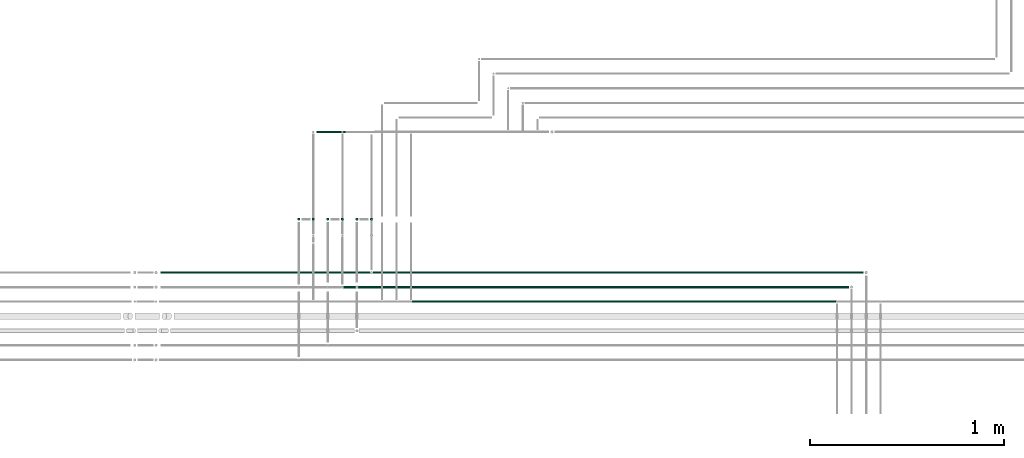
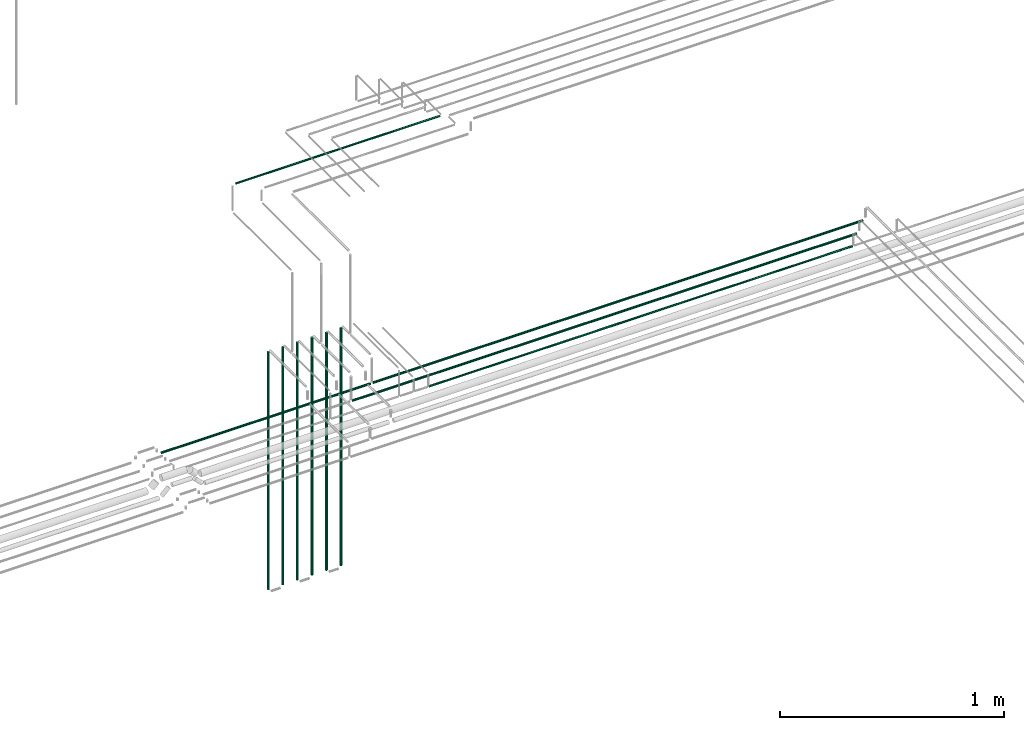
# One storey, part 29 of 331: 11 flow segments.
"""IFC2X3 building model written with IfcOpenShell, lengths in millimetres."""

from ifc_helpers import new_model, entity, si_unit, converted_unit, derived_unit, direction, frame, frame_2d, origin, origin_2d_with_axis, place, context, subcontext, project, spatial, circle, extrude, type_object, element, save


model = new_model("IFC2X3")

# Units and contexts
model_context = context("Model", 3, precision=0.01, world=origin(), true_north=direction((6.12303176911189e-17, 1.0)))
body_context = subcontext(model_context, "Body", "Model", "MODEL_VIEW")
ifc_project = project(units=[si_unit("LENGTHUNIT", "METRE", prefix="MILLI"), si_unit("AREAUNIT", "SQUARE_METRE"), si_unit("VOLUMEUNIT", "CUBIC_METRE"), converted_unit("PLANEANGLEUNIT", "DEGREE", entity("IfcRatioMeasure", 0.0174532925199433), si_unit("PLANEANGLEUNIT", "RADIAN"), dimensions=[0, 0, 0, 0, 0, 0, 0]), si_unit("MASSUNIT", "GRAM", prefix="KILO"), derived_unit("MASSDENSITYUNIT", [(si_unit("MASSUNIT", "GRAM", prefix="KILO"), 1), (si_unit("LENGTHUNIT", "METRE"), -3)]), derived_unit("MOMENTOFINERTIAUNIT", [(si_unit("LENGTHUNIT", "METRE"), 4)]), si_unit("TIMEUNIT", "SECOND"), si_unit("FREQUENCYUNIT", "HERTZ"), si_unit("THERMODYNAMICTEMPERATUREUNIT", "DEGREE_CELSIUS"), derived_unit("THERMALTRANSMITTANCEUNIT", [(si_unit("MASSUNIT", "GRAM", prefix="KILO"), 1), (si_unit("THERMODYNAMICTEMPERATUREUNIT", "KELVIN"), -1), (si_unit("TIMEUNIT", "SECOND"), -3)]), derived_unit("VOLUMETRICFLOWRATEUNIT", [(si_unit("LENGTHUNIT", "METRE"), 3), (si_unit("TIMEUNIT", "SECOND"), -1)]), derived_unit("MASSFLOWRATEUNIT", [(si_unit("MASSUNIT", "GRAM", prefix="KILO"), 1), (si_unit("TIMEUNIT", "SECOND"), -1)]), derived_unit("ROTATIONALFREQUENCYUNIT", [(si_unit("TIMEUNIT", "SECOND"), -1)]), si_unit("ELECTRICCURRENTUNIT", "AMPERE"), si_unit("ELECTRICVOLTAGEUNIT", "VOLT"), si_unit("POWERUNIT", "WATT"), si_unit("FORCEUNIT", "NEWTON", prefix="KILO"), si_unit("ILLUMINANCEUNIT", "LUX"), si_unit("LUMINOUSFLUXUNIT", "LUMEN"), si_unit("LUMINOUSINTENSITYUNIT", "CANDELA"), derived_unit("USERDEFINED", [(si_unit("MASSUNIT", "GRAM", prefix="KILO"), -1), (si_unit("LENGTHUNIT", "METRE"), -2), (si_unit("TIMEUNIT", "SECOND"), 3), (si_unit("LUMINOUSFLUXUNIT", "LUMEN"), 1)]), derived_unit("LINEARVELOCITYUNIT", [(si_unit("LENGTHUNIT", "METRE"), 1), (si_unit("TIMEUNIT", "SECOND"), -1)]), si_unit("PRESSUREUNIT", "PASCAL"), derived_unit("USERDEFINED", [(si_unit("LENGTHUNIT", "METRE"), -2), (si_unit("MASSUNIT", "GRAM", prefix="KILO"), 1), (si_unit("TIMEUNIT", "SECOND"), -2)]), derived_unit("LINEARFORCEUNIT", [(si_unit("MASSUNIT", "GRAM", prefix="KILO"), 1), (si_unit("LENGTHUNIT", "METRE"), 1), (si_unit("TIMEUNIT", "SECOND"), -2), (si_unit("LENGTHUNIT", "METRE"), -1)]), derived_unit("PLANARFORCEUNIT", [(si_unit("MASSUNIT", "GRAM", prefix="KILO"), 1), (si_unit("LENGTHUNIT", "METRE"), 1), (si_unit("TIMEUNIT", "SECOND"), -2), (si_unit("LENGTHUNIT", "METRE"), -2)])], contexts=[model_context])

# Site, building, storey
site_placement = place(None, frame((0.0, -0.00077364408347762, 0.0)))
site = spatial("IfcSite", under=ifc_project, at=site_placement, CompositionType="ELEMENT")
building_placement = place(site_placement, origin())
building = spatial("IfcBuilding", under=site, at=building_placement, CompositionType="ELEMENT")
storey_placement = place(building_placement, origin())
storey = spatial("IfcBuildingStorey", under=building, at=storey_placement, CompositionType="ELEMENT", Elevation=0.0)

# Flow segments
pipe_segment_type = type_object("IfcPipeSegmentType", PredefinedType="NOTDEFINED")
flow_segment_1_placement = place(storey_placement, frame((37929.2598936966, 16042.389397967, 6667.40472776408)))
element("IfcFlowSegment", 1, at=flow_segment_1_placement, inside=storey, type_object=pipe_segment_type, context=body_context, shape_type="SweptSolid", body=[
    extrude(circle(Radius=6.0, at=frame_2d((4.33146851719357e-12, 0.0), x_axis=(1.0, 0.0))), frame((0.0, 7.59527223592103, 7.59527223591562), z_axis=(1.0, 0.0, 0.0), x_axis=(0.0, 1.0, 0.0)), (0.0, 0.0, 1.0), 2528.7454797317),
])
flow_segment_2_placement = place(storey_placement, frame((37779.2598936966, 15967.389397967, 6667.40472776408)))
element("IfcFlowSegment", 2, at=flow_segment_2_placement, inside=storey, type_object=pipe_segment_type, context=body_context, shape_type="SweptSolid", body=[
    extrude(circle(Radius=6.0, at=frame_2d((4.33146851719357e-12, 0.0), x_axis=(1.0, 0.0))), frame((0.0, 7.59527223592103, 7.59527223591562), z_axis=(1.0, 0.0, 0.0), x_axis=(0.0, 1.0, 0.0)), (0.0, 0.0, 1.0), 2603.7454797317),
])
flow_segment_3_placement = place(storey_placement, frame((38132.0356581569, 15894.3893979669, 6669.40472776409)))
element("IfcFlowSegment", 3, at=flow_segment_3_placement, inside=storey, type_object=pipe_segment_type, context=body_context, shape_type="SweptSolid", body=[
    extrude(circle(Radius=4.0, at=frame_2d((-7.58006990508875e-11, -1.08286712929839e-12), x_axis=(1.0, 0.0))), frame((0.0, 5.59527223598863, 5.59527223591716), z_axis=(1.0, 0.0, 0.0), x_axis=(0.0, 1.0, 0.0)), (0.0, 0.0, 1.0), 2184.96971527141),
])
flow_segment_4_placement = place(building_placement, frame((37539.6646214607, 16317.389397967, 5514.0)))
element("IfcFlowSegment", 4, at=flow_segment_4_placement, inside=storey, type_object=pipe_segment_type, context=body_context, shape_type="SweptSolid", body=[
    extrude(circle(Radius=6.0, at=origin_2d_with_axis()), frame((7.59527223591454, 7.5952722359167, 0.0), z_axis=(0.0, 0.0, 1.0), x_axis=(-1.0, 0.0, 0.0)), (0.0, 0.0, 1.0), 1297.27361563519),
])
flow_segment_5_placement = place(building_placement, frame((37614.6646214607, 16317.389397967, 5514.0)))
element("IfcFlowSegment", 5, at=flow_segment_5_placement, inside=storey, type_object=pipe_segment_type, context=body_context, shape_type="SweptSolid", body=[
    extrude(circle(Radius=6.0, at=frame_2d((0.0, -2.16573425859679e-12), x_axis=(1.0, 0.0))), frame((7.59527223591454, 7.59527223591454, 0.0), z_axis=(0.0, 0.0, 1.0), x_axis=(-1.0, 0.0, 0.0)), (0.0, 0.0, 1.0), 1297.00000000002),
])
flow_segment_6_placement = place(storey_placement, frame((37689.6646214607, 16317.389397967, 5514.0)))
element("IfcFlowSegment", 6, at=flow_segment_6_placement, inside=storey, type_object=pipe_segment_type, context=body_context, shape_type="SweptSolid", body=[
    extrude(circle(Radius=6.0, at=origin_2d_with_axis()), frame((7.59527223591454, 7.5952722359167, 0.0), z_axis=(0.0, 0.0, 1.0), x_axis=(-1.0, 0.0, 0.0)), (0.0, 0.0, 1.0), 1297.0),
])
flow_segment_7_placement = place(storey_placement, frame((37764.6646214607, 16317.389397967, 5514.0)))
element("IfcFlowSegment", 7, at=flow_segment_7_placement, inside=storey, type_object=pipe_segment_type, context=body_context, shape_type="SweptSolid", body=[
    extrude(circle(Radius=6.0, at=frame_2d((0.0, -2.16573425859679e-12), x_axis=(1.0, 0.0))), frame((7.59527223591454, 7.59527223591454, 0.0), z_axis=(0.0, 0.0, 1.0), x_axis=(-1.0, 0.0, 0.0)), (0.0, 0.0, 1.0), 1297.00000000002),
])
flow_segment_8_placement = place(storey_placement, frame((37839.6646214607, 16317.389397967, 5514.0)))
element("IfcFlowSegment", 8, at=flow_segment_8_placement, inside=storey, type_object=pipe_segment_type, context=body_context, shape_type="SweptSolid", body=[
    extrude(circle(Radius=6.0, at=origin_2d_with_axis()), frame((7.59527223591454, 7.5952722359167, 0.0), z_axis=(0.0, 0.0, 1.0), x_axis=(-1.0, 0.0, 0.0)), (0.0, 0.0, 1.0), 1297.0),
])
flow_segment_9_placement = place(storey_placement, frame((37914.6646214607, 16317.389397967, 5514.0)))
element("IfcFlowSegment", 9, at=flow_segment_9_placement, inside=storey, type_object=pipe_segment_type, context=body_context, shape_type="SweptSolid", body=[
    extrude(circle(Radius=6.0, at=frame_2d((0.0, -2.16573425859679e-12), x_axis=(1.0, 0.0))), frame((7.59527223591454, 7.59527223591454, 0.0), z_axis=(0.0, 0.0, 1.0), x_axis=(-1.0, 0.0, 0.0)), (0.0, 0.0, 1.0), 1297.00000000002),
])
flow_segment_10_placement = place(storey_placement, frame((37639.2598936966, 16769.0717689152, 7419.40472776408)))
element("IfcFlowSegment", 10, at=flow_segment_10_placement, inside=storey, type_object=pipe_segment_type, context=body_context, shape_type="SweptSolid", body=[
    extrude(circle(Radius=4.0, at=frame_2d((-6.49720277579036e-12, 2.16573425859679e-12), x_axis=(1.0, 0.0))), frame((0.0, 5.59527223592149, 5.59527223591932), z_axis=(1.0, 0.0, 0.0), x_axis=(0.0, 1.0, 0.0)), (0.0, 0.0, 1.0), 1052.88285187767),
])
flow_segment_11_placement = place(storey_placement, frame((36835.4094162434, 16042.389397967, 6667.40472776408)))
element("IfcFlowSegment", 11, at=flow_segment_11_placement, inside=storey, type_object=pipe_segment_type, context=body_context, shape_type="SweptSolid", body=[
    extrude(circle(Radius=6.0, at=frame_2d((0.0, 1.08286712929839e-12), x_axis=(1.0, 0.0))), frame((0.0, 7.5952722359167, 7.5952722359167), z_axis=(1.0, 0.0, 0.0), x_axis=(0.0, -1.0, 0.0)), (0.0, 0.0, 1.0), 1079.85047745313),
])

save(model, "model.ifc")
